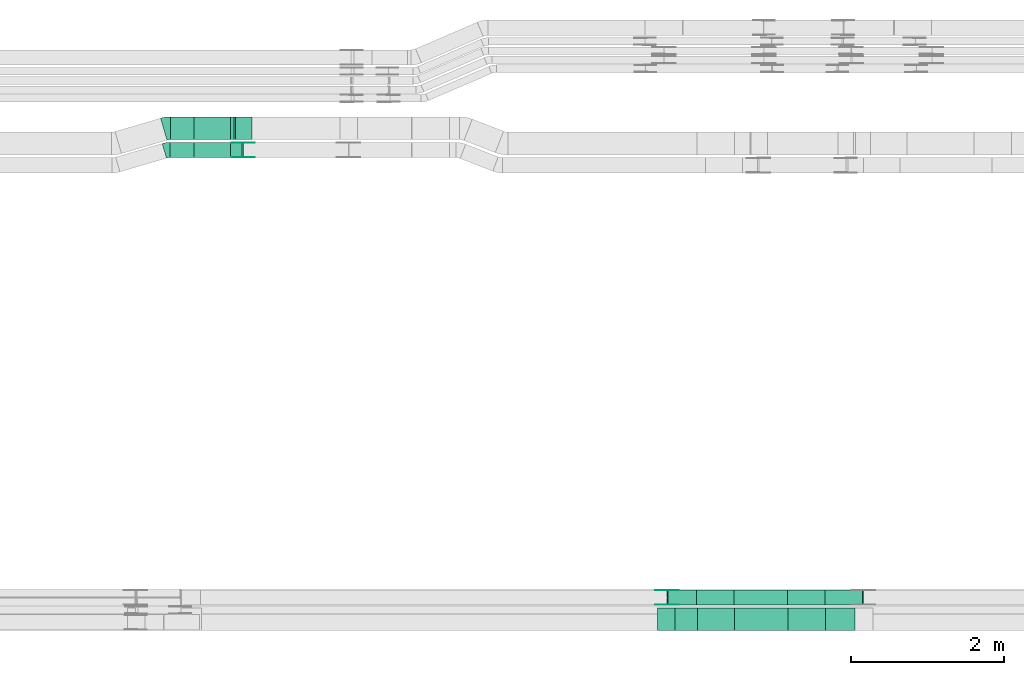
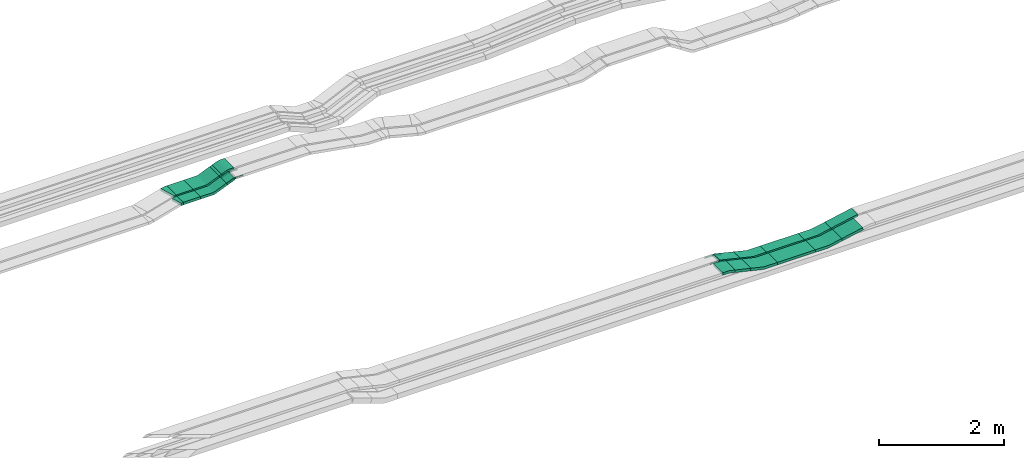
# One storey, part 14 of 28: 18 flow fittings, 10 flow segments.
"""IFC2X3 building model written with IfcOpenShell, lengths in millimetres."""

import ifcopenshell
import ifcopenshell.guid

model = None  # the IFC model being written
_history = None  # IfcOwnerHistory: only IFC2X3 demands one
_inside = {}  # id of a spatial element -> (the spatial element, [elements in it])
_under = {}  # id of a project, library or spatial element -> (it, [spatial elements below it])
_declared = {}  # id of a project -> (the project, [libraries it declares])
_typed = {}  # id of a type object -> (the type object, [elements of that type])
_made_of = {}  # id of a material, layer set ... -> (it, [elements and type objects made of it])


def new_model(schema):
    """Start an empty IFC model of exactly this schema.

    Asked for "IFC4X3", IfcOpenShell would pick the latest addendum, in which some entities
    have other attributes; the version numbers below select the first issue.
    IFC2X3 requires an IfcOwnerHistory on every rooted entity: one is made here for all.
    """
    global model, _history
    if schema == "IFC4X3":
        model = ifcopenshell.file(schema_version=(4, 3, 0, 0))
    else:
        model = ifcopenshell.file(schema=schema)
    _inside.clear()
    _under.clear()
    _declared.clear()
    _typed.clear()
    _made_of.clear()
    _history = None
    if model.schema == "IFC2X3":
        org = make("IfcOrganization", Name="unknown")
        user = make(
            "IfcPersonAndOrganization",
            ThePerson=make("IfcPerson", FamilyName="unknown"),
            TheOrganization=org,
        )
        app = make(
            "IfcApplication",
            ApplicationDeveloper=org,
            Version="unknown",
            ApplicationFullName="unknown",
            ApplicationIdentifier="unknown",
        )
        _history = make(
            "IfcOwnerHistory",
            OwningUser=user,
            OwningApplication=app,
            ChangeAction="ADDED",
            CreationDate=0,
        )
    return model


def make(cls, **values):
    """One entity of the class cls with the attributes given. An attribute that is None is left unset."""
    return model.create_entity(
        cls, **{name: value for name, value in values.items() if value is not None}
    )


def entity(cls, *values):
    """Any entity or typed value of the class cls, its attributes in the order of the schema. None: left unset."""
    e = model.create_entity(cls)
    for i, value in enumerate(values):
        if value is not None:
            e[i] = value
    return e


def rooted(cls, **values):
    """An entity with a GlobalId (a new one), such as an element, a storey or a relation."""
    return make(cls, GlobalId=ifcopenshell.guid.new(), OwnerHistory=_history, **values)


def si_unit(unit_type, name, prefix=None):
    """IfcSIUnit, for example si_unit("LENGTHUNIT", "METRE", prefix="MILLI")."""
    return make("IfcSIUnit", UnitType=unit_type, Prefix=prefix, Name=name)


def converted_unit(unit_type, name, factor, base, dimensions=None, offset=None):
    """IfcConversionBasedUnit, such as the inch: factor (a typed value) times the base unit."""
    return make(
        "IfcConversionBasedUnit"
        if offset is None
        else "IfcConversionBasedUnitWithOffset",
        ConversionOffset=offset,
        Dimensions=None
        if dimensions is None
        else entity("IfcDimensionalExponents", *dimensions),
        UnitType=unit_type,
        Name=name,
        ConversionFactor=make(
            "IfcMeasureWithUnit", ValueComponent=factor, UnitComponent=base
        ),
    )


def derived_unit(unit_type, elements):
    """IfcDerivedUnit: a product of units, each with its exponent."""
    return make(
        "IfcDerivedUnit",
        Elements=[
            make("IfcDerivedUnitElement", Unit=unit, Exponent=power)
            for unit, power in elements
        ],
        UnitType=unit_type,
    )


def assignment(units):
    """IfcUnitAssignment: the units of a project."""
    return None if units is None else make("IfcUnitAssignment", Units=units)


def point(xyz):
    """IfcCartesianPoint."""
    return None if xyz is None else make("IfcCartesianPoint", Coordinates=xyz)


def direction(xyz):
    """IfcDirection."""
    return None if xyz is None else make("IfcDirection", DirectionRatios=xyz)


def frame(location, z_axis=None, x_axis=None):
    """IfcAxis2Placement3D, a coordinate frame: its origin and axes. An axis left out is left unset."""
    return make(
        "IfcAxis2Placement3D",
        Location=point(location),
        Axis=direction(z_axis),
        RefDirection=direction(x_axis),
    )


def frame_2d(location, x_axis=None):
    """IfcAxis2Placement2D, a coordinate frame in the plane: its origin and x axis."""
    return make(
        "IfcAxis2Placement2D", Location=point(location), RefDirection=direction(x_axis)
    )


def origin():
    """The frame at (0, 0, 0) with its axes left unset."""
    return frame((0.0, 0.0, 0.0))


def origin_2d_with_axis():
    """The frame at (0, 0) in the plane with the x axis (1, 0) written out."""
    return frame_2d((0.0, 0.0), x_axis=(1.0, 0.0))


def place(relative_to, where):
    """IfcLocalPlacement: puts the frame where relative to a parent placement (None: the world)."""
    return make(
        "IfcLocalPlacement", PlacementRelTo=relative_to, RelativePlacement=where
    )


def context(
    kind, dimensions, precision=None, world=None, true_north=None, identifier=None
):
    """IfcGeometricRepresentationContext, for example the 3D "Model" context."""
    return make(
        "IfcGeometricRepresentationContext",
        ContextIdentifier=identifier,
        ContextType=kind,
        CoordinateSpaceDimension=dimensions,
        Precision=precision,
        WorldCoordinateSystem=world,
        TrueNorth=true_north,
    )


def subcontext(parent, identifier, kind, view, scale=None):
    """IfcGeometricRepresentationSubContext, for example "Body" below "Model"."""
    return make(
        "IfcGeometricRepresentationSubContext",
        ContextIdentifier=identifier,
        ContextType=kind,
        ParentContext=parent,
        TargetScale=scale,
        TargetView=view,
    )


def project(units=None, contexts=None):
    """IfcProject with its units and contexts."""
    return rooted(
        "IfcProject",
        Name="project",
        RepresentationContexts=contexts,
        UnitsInContext=assignment(units),
    )


def spatial(cls, under=None, at=None, **own):
    """A site, building, storey or space (cls), placed at a placement, below another one or the project."""
    s = rooted(cls, ObjectPlacement=at, **own)
    if under is not None:
        _under.setdefault(under.id(), (under, []))[1].append(s)
    return s


def polyline(points):
    """IfcPolyline through the points."""
    return make("IfcPolyline", Points=[point(p) for p in points])


def circle_curve(where, radius):
    """IfcCircle in the frame where."""
    return make("IfcCircle", Position=where, Radius=radius)


def parameter(value):
    """IfcParameterValue: where a trimmed curve begins or ends, as a parameter of its basis curve."""
    return model.create_entity("IfcParameterValue", value)


def trimmed(basis, trim1, trim2, sense, master):
    """IfcTrimmedCurve: the piece of a basis curve between two trims."""
    return make(
        "IfcTrimmedCurve",
        BasisCurve=basis,
        Trim1=trim1,
        Trim2=trim2,
        SenseAgreement=sense,
        MasterRepresentation=master,
    )


def segment(curve, same_sense, transition):
    """IfcCompositeCurveSegment."""
    return make(
        "IfcCompositeCurveSegment",
        Transition=transition,
        SameSense=same_sense,
        ParentCurve=curve,
    )


def composite_curve(segments, self_intersect=None):
    """IfcCompositeCurve: segments joined end to end."""
    return make("IfcCompositeCurve", Segments=segments, SelfIntersect=self_intersect)


def profile(cls, at=None, kind="AREA", **sizes):
    """A parametric profile (cls). Its sizes go by their IFC names, for example OverallWidth=200.0."""
    return make(cls, ProfileType=kind, Position=at, **sizes)


def rectangle(**sizes):
    """IfcRectangleProfileDef."""
    return profile("IfcRectangleProfileDef", **sizes)


def outline(outer, holes=None, kind="AREA"):
    """IfcArbitraryClosedProfileDef: a profile drawn as a closed curve; with holes, ...WithVoids."""
    if holes is None:
        return make("IfcArbitraryClosedProfileDef", ProfileType=kind, OuterCurve=outer)
    return make(
        "IfcArbitraryProfileDefWithVoids",
        ProfileType=kind,
        OuterCurve=outer,
        InnerCurves=holes,
    )


def extrude(swept, where, along, depth):
    """IfcExtrudedAreaSolid: the profile swept, set in the frame where, extruded along a direction by depth."""
    return make(
        "IfcExtrudedAreaSolid",
        SweptArea=swept,
        Position=where,
        ExtrudedDirection=direction(along),
        Depth=depth,
    )


def shape(context_of_items, identifier, shape_type, items):
    """IfcShapeRepresentation: the items that make up one representation, for example the "Body"."""
    return make(
        "IfcShapeRepresentation",
        ContextOfItems=context_of_items,
        RepresentationIdentifier=identifier,
        RepresentationType=shape_type,
        Items=items,
    )


def source(mapping_origin, context_of_items, identifier, shape_type, items):
    """IfcRepresentationMap: a shape defined once, which mapped items show again and again."""
    return make(
        "IfcRepresentationMap",
        MappingOrigin=mapping_origin,
        MappedRepresentation=shape(context_of_items, identifier, shape_type, items),
    )


def transform(
    local_origin,
    x_axis=None,
    y_axis=None,
    z_axis=None,
    scale=None,
    scale2=None,
    scale3=None,
    uniform=True,
):
    """IfcCartesianTransformationOperator3D, or its non-uniform kind. x_axis, y_axis, z_axis: its Axis1, 2, 3."""
    if uniform:
        return make(
            "IfcCartesianTransformationOperator3D",
            Axis1=direction(x_axis),
            Axis2=direction(y_axis),
            LocalOrigin=point(local_origin),
            Scale=scale,
            Axis3=direction(z_axis),
        )
    return make(
        "IfcCartesianTransformationOperator3DnonUniform",
        Axis1=direction(x_axis),
        Axis2=direction(y_axis),
        LocalOrigin=point(local_origin),
        Scale=scale,
        Axis3=direction(z_axis),
        Scale2=scale2,
        Scale3=scale3,
    )


def mapped(mapping_source, mapping_target):
    """IfcMappedItem: shows the shape of a source again, moved by a transform."""
    return make(
        "IfcMappedItem", MappingSource=mapping_source, MappingTarget=mapping_target
    )


def material(Name=None, Category=None):
    """IfcMaterial."""
    return make("IfcMaterial", Name=Name, Category=Category)


def made_of(thing, what):
    """Note that an element or type object is made of a material, layer set ...; save() writes the relation."""
    if what is not None:
        _made_of.setdefault(what.id(), (what, []))[1].append(thing)
    return thing


def type_object(cls, material=None, **own):
    """A type object (cls), such as IfcWallType, which elements share."""
    return made_of(rooted(cls, **own), material)


def type_shapes(of_type, sources):
    """Give a type object the sources (RepresentationMaps) that its elements show as mapped items."""
    of_type.RepresentationMaps = sources


def element(
    cls,
    number,
    at=None,
    inside=None,
    cuts=None,
    type_object=None,
    material=None,
    context=None,
    identifier="Body",
    shape_type=None,
    held_by="IfcProductDefinitionShape",
    body=None,
    shapes=None,
    **own,
):
    """One element of the class cls, such as IfcWall. Its Tag is "e" and its number.

    at: its placement. inside: the storey or other place that contains it. cuts: it is an
    opening in that element (IfcRelVoidsElement). A single representation is given by context,
    identifier, shape_type and body (its items); several are given by shapes. held_by: the class
    of the entity that holds the representations. save() writes the other relations.
    """
    e = rooted(cls, Tag="e%d" % number, ObjectPlacement=at, **own)
    if body is not None:
        shapes = [shape(context, identifier, shape_type, body)]
    if shapes is not None:
        e.Representation = make(held_by, Representations=shapes)
    if inside is not None:
        _inside.setdefault(inside.id(), (inside, []))[1].append(e)
    if cuts is not None:
        rooted(
            "IfcRelVoidsElement", RelatingBuildingElement=cuts, RelatedOpeningElement=e
        )
    if type_object is not None:
        _typed.setdefault(type_object.id(), (type_object, []))[1].append(e)
    return made_of(e, material)


def aggregate(whole, parts):
    """IfcRelAggregates: a whole, such as a stair, and the parts it consists of."""
    return rooted("IfcRelAggregates", RelatingObject=whole, RelatedObjects=parts)


def save(model, path):
    """Write the relations noted so far, then the file.

    IfcRelAggregates (storeys below a building ...), IfcRelContainedInSpatialStructure (elements
    in a storey), IfcRelDefinesByType, IfcRelAssociatesMaterial and IfcRelDeclares: one each for
    every whole, place, type object, material and project.
    """
    for whole, parts in _under.values():
        aggregate(whole, parts)
    for where, things in _inside.values():
        rooted(
            "IfcRelContainedInSpatialStructure",
            RelatedElements=things,
            RelatingStructure=where,
        )
    for kind, things in _typed.values():
        rooted("IfcRelDefinesByType", RelatedObjects=things, RelatingType=kind)
    for what, things in _made_of.values():
        rooted("IfcRelAssociatesMaterial", RelatedObjects=things, RelatingMaterial=what)
    for by, libraries in _declared.values():
        rooted("IfcRelDeclares", RelatingContext=by, RelatedDefinitions=libraries)
    model.write(path)


model = new_model("IFC2X3")

# Units and contexts
model_context = context("Model", 3, precision=0.01, world=origin(), true_north=direction((6.12303176911189e-17, 1.0)))
body_context = subcontext(model_context, "Body", "Model", "MODEL_VIEW")
ifc_project = project(units=[si_unit("LENGTHUNIT", "METRE", prefix="MILLI"), si_unit("AREAUNIT", "SQUARE_METRE"), si_unit("VOLUMEUNIT", "CUBIC_METRE"), converted_unit("PLANEANGLEUNIT", "DEGREE", entity("IfcRatioMeasure", 0.0174532925199433), si_unit("PLANEANGLEUNIT", "RADIAN"), dimensions=[0, 0, 0, 0, 0, 0, 0]), si_unit("MASSUNIT", "GRAM", prefix="KILO"), derived_unit("MASSDENSITYUNIT", [(si_unit("MASSUNIT", "GRAM", prefix="KILO"), 1), (si_unit("LENGTHUNIT", "METRE"), -3)]), derived_unit("MOMENTOFINERTIAUNIT", [(si_unit("LENGTHUNIT", "METRE"), 4)]), si_unit("TIMEUNIT", "SECOND"), si_unit("FREQUENCYUNIT", "HERTZ"), si_unit("THERMODYNAMICTEMPERATUREUNIT", "DEGREE_CELSIUS"), derived_unit("THERMALTRANSMITTANCEUNIT", [(si_unit("MASSUNIT", "GRAM", prefix="KILO"), 1), (si_unit("THERMODYNAMICTEMPERATUREUNIT", "KELVIN"), -1), (si_unit("TIMEUNIT", "SECOND"), -3)]), derived_unit("VOLUMETRICFLOWRATEUNIT", [(si_unit("LENGTHUNIT", "METRE"), 3), (si_unit("TIMEUNIT", "SECOND"), -1)]), derived_unit("MASSFLOWRATEUNIT", [(si_unit("MASSUNIT", "GRAM", prefix="KILO"), 1), (si_unit("TIMEUNIT", "SECOND"), -1)]), derived_unit("ROTATIONALFREQUENCYUNIT", [(si_unit("TIMEUNIT", "SECOND"), -1)]), si_unit("ELECTRICCURRENTUNIT", "AMPERE"), si_unit("ELECTRICVOLTAGEUNIT", "VOLT"), si_unit("POWERUNIT", "WATT"), si_unit("FORCEUNIT", "NEWTON", prefix="KILO"), si_unit("ILLUMINANCEUNIT", "LUX"), si_unit("LUMINOUSFLUXUNIT", "LUMEN"), si_unit("LUMINOUSINTENSITYUNIT", "CANDELA"), derived_unit("USERDEFINED", [(si_unit("MASSUNIT", "GRAM", prefix="KILO"), -1), (si_unit("LENGTHUNIT", "METRE"), -2), (si_unit("TIMEUNIT", "SECOND"), 3), (si_unit("LUMINOUSFLUXUNIT", "LUMEN"), 1)]), derived_unit("LINEARVELOCITYUNIT", [(si_unit("LENGTHUNIT", "METRE"), 1), (si_unit("TIMEUNIT", "SECOND"), -1)]), si_unit("PRESSUREUNIT", "PASCAL"), derived_unit("USERDEFINED", [(si_unit("LENGTHUNIT", "METRE"), -2), (si_unit("MASSUNIT", "GRAM", prefix="KILO"), 1), (si_unit("TIMEUNIT", "SECOND"), -2)]), derived_unit("LINEARFORCEUNIT", [(si_unit("MASSUNIT", "GRAM", prefix="KILO"), 1), (si_unit("LENGTHUNIT", "METRE"), 1), (si_unit("TIMEUNIT", "SECOND"), -2), (si_unit("LENGTHUNIT", "METRE"), -1)]), derived_unit("PLANARFORCEUNIT", [(si_unit("MASSUNIT", "GRAM", prefix="KILO"), 1), (si_unit("LENGTHUNIT", "METRE"), 1), (si_unit("TIMEUNIT", "SECOND"), -2), (si_unit("LENGTHUNIT", "METRE"), -2)])], contexts=[model_context])

# Site, building, storey
site_placement = place(None, origin())
site = spatial("IfcSite", under=ifc_project, at=site_placement, CompositionType="ELEMENT")
building_placement = place(site_placement, origin())
building = spatial("IfcBuilding", under=site, at=building_placement, CompositionType="ELEMENT")
storey_placement = place(building_placement, frame((0.0, 0.0, 15900.0)))
storey = spatial("IfcBuildingStorey", under=building, at=storey_placement, CompositionType="ELEMENT", Elevation=15900.0)

# Flow segments
cable_carrier_segment_type = type_object("IfcCableCarrierSegmentType", PredefinedType="CABLETRAYSEGMENT")
flow_segment_1_placement = place(storey_placement, frame((50193.5, 8550.15, 2670.0)))
element("IfcFlowSegment", 1, at=flow_segment_1_placement, inside=storey, type_object=cable_carrier_segment_type, context=body_context, shape_type="SweptSolid", body=[
    extrude(rectangle(XDim=698.184892642371, YDim=200.0, at=origin_2d_with_axis()), frame((349.09, 100.0, 0.0), z_axis=(0.0, 0.0, 1.0), x_axis=(-1.0, 0.0, 0.0)), (0.0, 0.0, 1.0), 50.0000000000016),
])
flow_segment_2_placement = place(storey_placement, frame((50203.18, 8215.15, 2670.0)))
element("IfcFlowSegment", 2, at=flow_segment_2_placement, inside=storey, type_object=cable_carrier_segment_type, context=body_context, shape_type="SweptSolid", body=[
    extrude(rectangle(XDim=698.304534220649, YDim=300.000000000001, at=origin_2d_with_axis()), frame((349.15, 150.0, 0.0), z_axis=(0.0, 0.0, 1.0), x_axis=(-1.0, 0.0, 0.0)), (0.0, 0.0, 1.0), 50.0000000000016),
])
flow_segment_3_placement = place(storey_placement, frame((49413.95, 8215.15, 2727.48)))
element("IfcFlowSegment", 3, at=flow_segment_3_placement, inside=storey, type_object=cable_carrier_segment_type, context=body_context, shape_type="SweptSolid", body=[
    extrude(rectangle(XDim=50.0000000000005, YDim=296.977603274496, at=frame_2d((0.0, 0.0), x_axis=(0.0, 1.0))), frame((150.29, 0.0, 58.04), z_axis=(0.0, 1.0, 0.0), x_axis=(-0.973915582918312, 0.0, 0.226910637363885)), (0.0, 0.0, 1.0), 300.000000000001),
])
flow_segment_4_placement = place(storey_placement, frame((51391.6, 8215.15, 2719.91)))
element("IfcFlowSegment", 4, at=flow_segment_4_placement, inside=storey, type_object=cable_carrier_segment_type, context=body_context, shape_type="SweptSolid", body=[
    extrude(rectangle(XDim=50.0000000000021, YDim=300.000000000001, at=origin_2d_with_axis()), frame((4.94, 150.0, 24.51), z_axis=(0.980265659659677, 0.0, 0.197684689574023), x_axis=(-0.197684689574023, 0.0, 0.980265659659677)), (0.0, 0.0, 1.0), 395.138063612391),
])
flow_segment_5_placement = place(storey_placement, frame((49317.61, 8550.15, 2729.27)))
element("IfcFlowSegment", 5, at=flow_segment_5_placement, inside=storey, type_object=cable_carrier_segment_type, context=body_context, shape_type="SweptSolid", body=[
    extrude(rectangle(XDim=50.0000000000019, YDim=200.0, at=origin_2d_with_axis()), frame((5.84, 100.0, 114.69), z_axis=(0.972286194973467, 0.0, -0.233793830252249), x_axis=(0.233793830252249, 0.0, 0.972286194973467)), (0.0, 0.0, 1.0), 386.603864196462),
])
flow_segment_6_placement = place(storey_placement, frame((51381.8, 8550.15, 2719.91)))
element("IfcFlowSegment", 6, at=flow_segment_6_placement, inside=storey, type_object=cable_carrier_segment_type, context=body_context, shape_type="SweptSolid", body=[
    extrude(rectangle(XDim=50.0000000000021, YDim=200.0, at=origin_2d_with_axis()), frame((4.94, 100.0, 24.51), z_axis=(0.980265659659677, 0.0, 0.197684689574023), x_axis=(-0.197684689574023, 0.0, 0.980265659659677)), (0.0, 0.0, 1.0), 504.893418932324),
])
flow_segment_7_placement = place(storey_placement, frame((42826.4, 14635.03, 2675.0)))
element("IfcFlowSegment", 7, at=flow_segment_7_placement, inside=storey, type_object=cable_carrier_segment_type, context=body_context, shape_type="SweptSolid", body=[
    extrude(rectangle(XDim=307.551244257685, YDim=300.000000000001, at=origin_2d_with_axis()), frame((153.78, 150.0, 0.0)), (0.0, 0.0, 1.0), 50.0000000000016),
])
flow_segment_8_placement = place(storey_placement, frame((42819.2, 14400.03, 2675.0)))
element("IfcFlowSegment", 8, at=flow_segment_8_placement, inside=storey, type_object=cable_carrier_segment_type, context=body_context, shape_type="SweptSolid", body=[
    extrude(rectangle(XDim=314.751695724342, YDim=199.999999999998, at=origin_2d_with_axis()), frame((157.38, 100.0, 0.0), z_axis=(0.0, 0.0, 1.0), x_axis=(-1.0, 0.0, 0.0)), (0.0, 0.0, 1.0), 50.0000000000016),
])
flow_segment_9_placement = place(storey_placement, frame((43614.81, 14635.03, 2774.46)))
element("IfcFlowSegment", 9, at=flow_segment_9_placement, inside=storey, type_object=cable_carrier_segment_type, context=body_context, shape_type="SweptSolid", body=[
    extrude(rectangle(XDim=49.9999999999987, YDim=48.6041297172027, at=frame_2d((0.0, 0.0), x_axis=(0.0, 1.0))), frame((32.02, 0.0, 32.4), z_axis=(0.0, 1.0, 0.0), x_axis=(0.92387953251118, 0.0, 0.382683432365348)), (0.0, 0.0, 1.0), 300.000000000001),
])
flow_segment_10_placement = place(storey_placement, frame((43614.81, 14400.03, 2774.46)))
element("IfcFlowSegment", 10, at=flow_segment_10_placement, inside=storey, type_object=cable_carrier_segment_type, context=body_context, shape_type="SweptSolid", body=[
    extrude(rectangle(XDim=49.9999999999987, YDim=156.412966816902, at=frame_2d((0.0, 0.0), x_axis=(0.0, 1.0))), frame((81.82, 0.0, 53.03), z_axis=(0.0, 1.0, 0.0), x_axis=(0.923879532511178, 0.0, 0.382683432365351)), (0.0, 0.0, 1.0), 199.999999999998),
])

# Flow fittings
ifc_material_1 = material()
cable_carrier_fitting_type_1 = type_object("IfcCableCarrierFittingType", Name="470_DKC_S5_CS 90 internal vertical angle:-", PredefinedType="NOTDEFINED", material=ifc_material_1)
shared_shape_1 = source(origin(), body_context, "Body", "SweptSolid", [
    extrude(outline(composite_curve([segment(polyline([(-248.69, -40.12), (-14.36, -40.12)]), True, "CONTINUOUS"), segment(trimmed(circle_curve(frame_2d((-14.36, 124.88), x_axis=(0.0, -1.0)), 164.999999999999), [parameter(0.0)], [parameter(13.115255993311)], True, "PARAMETER"), True, "CONTINUOUS"), segment(polyline([(23.08, -35.82), (251.31, 17.36)]), True, "CONTINUOUS"), segment(polyline([(251.31, 17.36), (239.96, 66.05)]), True, "CONTINUOUS"), segment(polyline([(239.96, 66.05), (11.74, 12.88)]), True, "CONTINUOUS"), segment(trimmed(circle_curve(frame_2d((-14.36, 124.88), x_axis=(0.0, -1.0)), 114.999999999999), [parameter(0.0)], [parameter(13.115255993311)], True, "PARAMETER"), False, "CONTINUOUS"), segment(polyline([(-14.36, 9.88), (-248.69, 9.88)]), True, "CONTINUOUS"), segment(polyline([(-248.69, 9.88), (-248.69, -40.12)]), True, "CONTINUOUS")], self_intersect=False)), frame((-1.74, 15.12, -150.0)), (0.0, 0.0, 1.0), 300.0),
])
type_shapes(cable_carrier_fitting_type_1, [shared_shape_1])
flow_fitting_1_placement = place(storey_placement, frame((49952.75, 8365.15, 2695.0), z_axis=(0.0, 1.0, 0.0), x_axis=(-1.0, 0.0, 0.0)))
element("IfcFlowFitting", 11, at=flow_fitting_1_placement, inside=storey, type_object=cable_carrier_fitting_type_1, material=ifc_material_1, Name="470_DKC_S5_CS 90 internal vertical angle:-", ObjectType="470_DKC_S5_CS 90 internal vertical angle:-", context=body_context, shape_type="MappedRepresentation", body=[
    mapped(shared_shape_1, transform((0.0, 0.0, 0.0), scale=1.0)),
])
cable_carrier_fitting_type_2 = type_object("IfcCableCarrierFittingType", Name="470_DKC_S5_CD 90 external vertical angle:-", PredefinedType="NOTDEFINED", material=ifc_material_1)
shared_shape_2 = source(origin(), body_context, "Body", "SweptSolid", [
    extrude(outline(composite_curve([segment(polyline([(-112.78, -32.52), (-18.1, -32.52)]), True, "CONTINUOUS"), segment(trimmed(circle_curve(frame_2d((-18.1, 157.48), x_axis=(0.0, -1.0)), 189.999999999999), [parameter(0.0)], [parameter(13.1152559933101)], True, "PARAMETER"), True, "CONTINUOUS"), segment(polyline([(25.01, -27.57), (117.22, -6.08)]), True, "CONTINUOUS"), segment(polyline([(117.22, -6.08), (105.87, 42.61)]), True, "CONTINUOUS"), segment(polyline([(105.87, 42.61), (13.66, 21.13)]), True, "CONTINUOUS"), segment(trimmed(circle_curve(frame_2d((-18.1, 157.48), x_axis=(0.0, -1.0)), 139.999999999999), [parameter(0.0)], [parameter(13.1152559933101)], True, "PARAMETER"), False, "CONTINUOUS"), segment(polyline([(-18.1, 17.48), (-112.78, 17.48)]), True, "CONTINUOUS"), segment(polyline([(-112.78, 17.48), (-112.78, -32.52)]), True, "CONTINUOUS")], self_intersect=False)), frame((-0.86, 7.52, -150.0)), (0.0, 0.0, 1.0), 300.0),
])
type_shapes(cable_carrier_fitting_type_2, [shared_shape_2])
flow_fitting_2_placement = place(storey_placement, frame((49308.94, 8365.15, 2845.0), z_axis=(0.0, 1.0, 0.0), x_axis=(1.0, 0.0, 0.0)))
element("IfcFlowFitting", 12, at=flow_fitting_2_placement, inside=storey, type_object=cable_carrier_fitting_type_2, material=ifc_material_1, Name="470_DKC_S5_CD 90 external vertical angle:-", ObjectType="470_DKC_S5_CD 90 external vertical angle:-", context=body_context, shape_type="MappedRepresentation", body=[
    mapped(shared_shape_2, transform((0.0, 0.0, 0.0), scale=1.0)),
])
cable_carrier_fitting_type_3 = type_object("IfcCableCarrierFittingType", Name="470_DKC_S5_CS 90 internal vertical angle:-", PredefinedType="NOTDEFINED", material=ifc_material_1)
shared_shape_3 = source(origin(), body_context, "Body", "SweptSolid", [
    extrude(outline(composite_curve([segment(polyline([(-248.69, -38.05), (-12.67, -38.05)]), True, "CONTINUOUS"), segment(trimmed(circle_curve(frame_2d((-12.67, 126.95), x_axis=(0.0, -1.0)), 164.999999999999), [parameter(0.0)], [parameter(11.4015985350609)], True, "PARAMETER"), True, "CONTINUOUS"), segment(polyline([(19.94, -34.79), (251.31, 11.87)]), True, "CONTINUOUS"), segment(polyline([(251.31, 11.87), (241.42, 60.88)]), True, "CONTINUOUS"), segment(polyline([(241.42, 60.88), (10.06, 14.22)]), True, "CONTINUOUS"), segment(trimmed(circle_curve(frame_2d((-12.67, 126.95), x_axis=(0.0, -1.0)), 114.999999999999), [parameter(0.0)], [parameter(11.4015985350609)], True, "PARAMETER"), False, "CONTINUOUS"), segment(polyline([(-12.67, 11.95), (-248.69, 11.95)]), True, "CONTINUOUS"), segment(polyline([(-248.69, 11.95), (-248.69, -38.05)]), True, "CONTINUOUS")], self_intersect=False)), frame((-1.3, 13.05, -150.0)), (0.0, 0.0, 1.0), 300.0),
])
type_shapes(cable_carrier_fitting_type_3, [shared_shape_3])
flow_fitting_3_placement = place(storey_placement, frame((51151.48, 8365.15, 2695.0), z_axis=(0.0, -1.0, 0.0), x_axis=(1.0, 0.0, 0.0)))
element("IfcFlowFitting", 13, at=flow_fitting_3_placement, inside=storey, type_object=cable_carrier_fitting_type_3, material=ifc_material_1, Name="470_DKC_S5_CS 90 internal vertical angle:-", ObjectType="470_DKC_S5_CS 90 internal vertical angle:-", context=body_context, shape_type="MappedRepresentation", body=[
    mapped(shared_shape_3, transform((0.0, 0.0, 0.0), scale=1.0)),
])
cable_carrier_fitting_type_4 = type_object("IfcCableCarrierFittingType", Name="470_DKC_S5_CS 90 internal vertical angle:-", PredefinedType="NOTDEFINED", material=ifc_material_1)
shared_shape_4 = source(origin(), body_context, "Body", "SweptSolid", [
    extrude(outline(composite_curve([segment(polyline([(-248.7, -40.61), (-14.74, -40.61)]), True, "CONTINUOUS"), segment(trimmed(circle_curve(frame_2d((-14.74, 124.39), x_axis=(0.0, -1.0)), 164.999999999999), [parameter(0.0)], [parameter(13.5205338655362)], True, "PARAMETER"), True, "CONTINUOUS"), segment(polyline([(23.83, -36.04), (251.3, 18.66)]), True, "CONTINUOUS"), segment(polyline([(251.3, 18.66), (239.61, 67.27)]), True, "CONTINUOUS"), segment(polyline([(239.61, 67.27), (12.14, 12.57)]), True, "CONTINUOUS"), segment(trimmed(circle_curve(frame_2d((-14.74, 124.39), x_axis=(0.0, -1.0)), 114.999999999999), [parameter(0.0)], [parameter(13.5205338655362)], True, "PARAMETER"), False, "CONTINUOUS"), segment(polyline([(-14.74, 9.39), (-248.7, 9.39)]), True, "CONTINUOUS"), segment(polyline([(-248.7, 9.39), (-248.7, -40.61)]), True, "CONTINUOUS")], self_intersect=False)), frame((-1.85, 15.61, -100.0)), (0.0, 0.0, 1.0), 200.0),
])
type_shapes(cable_carrier_fitting_type_4, [shared_shape_4])
flow_fitting_4_placement = place(storey_placement, frame((49942.95, 8650.15, 2695.0), z_axis=(0.0, 1.0, 0.0), x_axis=(-1.0, 0.0, 0.0)))
element("IfcFlowFitting", 14, at=flow_fitting_4_placement, inside=storey, type_object=cable_carrier_fitting_type_4, material=ifc_material_1, Name="470_DKC_S5_CS 90 internal vertical angle:-", ObjectType="470_DKC_S5_CS 90 internal vertical angle:-", context=body_context, shape_type="MappedRepresentation", body=[
    mapped(shared_shape_4, transform((0.0, 0.0, 0.0), scale=1.0)),
])
cable_carrier_fitting_type_5 = type_object("IfcCableCarrierFittingType", Name="470_DKC_S5_CS 90 internal vertical angle:-", PredefinedType="NOTDEFINED", material=ifc_material_1)
shared_shape_5 = source(origin(), body_context, "Body", "SweptSolid", [
    extrude(outline(composite_curve([segment(polyline([(-248.69, -38.05), (-12.67, -38.05)]), True, "CONTINUOUS"), segment(trimmed(circle_curve(frame_2d((-12.67, 126.95), x_axis=(0.0, -1.0)), 164.999999999999), [parameter(0.0)], [parameter(11.4015985350609)], True, "PARAMETER"), True, "CONTINUOUS"), segment(polyline([(19.94, -34.79), (251.31, 11.87)]), True, "CONTINUOUS"), segment(polyline([(251.31, 11.87), (241.42, 60.88)]), True, "CONTINUOUS"), segment(polyline([(241.42, 60.88), (10.06, 14.22)]), True, "CONTINUOUS"), segment(trimmed(circle_curve(frame_2d((-12.67, 126.95), x_axis=(0.0, -1.0)), 114.999999999999), [parameter(0.0)], [parameter(11.4015985350609)], True, "PARAMETER"), False, "CONTINUOUS"), segment(polyline([(-12.67, 11.95), (-248.69, 11.95)]), True, "CONTINUOUS"), segment(polyline([(-248.69, 11.95), (-248.69, -38.05)]), True, "CONTINUOUS")], self_intersect=False)), frame((-1.3, 13.05, -100.0)), (0.0, 0.0, 1.0), 200.0),
])
type_shapes(cable_carrier_fitting_type_5, [shared_shape_5])
flow_fitting_5_placement = place(storey_placement, frame((51141.68, 8650.15, 2695.0), z_axis=(0.0, -1.0, 0.0), x_axis=(1.0, 0.0, 0.0)))
element("IfcFlowFitting", 15, at=flow_fitting_5_placement, inside=storey, type_object=cable_carrier_fitting_type_5, material=ifc_material_1, Name="470_DKC_S5_CS 90 internal vertical angle:-", ObjectType="470_DKC_S5_CS 90 internal vertical angle:-", context=body_context, shape_type="MappedRepresentation", body=[
    mapped(shared_shape_5, transform((0.0, 0.0, 0.0), scale=1.0)),
])
ifc_material_2 = material(Name="G")
cable_carrier_fitting_type_6 = type_object("IfcCableCarrierFittingType", PredefinedType="NOTDEFINED", material=ifc_material_2)
shared_shape_6 = source(origin(), body_context, "Body", "SweptSolid", [
    extrude(outline(composite_curve([segment(trimmed(circle_curve(frame_2d((-44.59, 0.0), x_axis=(1.0, 0.0)), 12.5), [parameter(90.0000000000007)], [parameter(270.0)], True, "PARAMETER"), True, "CONTINUOUS"), segment(polyline([(-44.59, -12.5), (-33.09, -12.5)]), True, "CONTINUOUS"), segment(polyline([(-33.09, -12.5), (-31.23, -14.5)]), True, "CONTINUOUS"), segment(polyline([(-31.23, -14.5), (108.91, -14.5)]), True, "CONTINUOUS"), segment(polyline([(108.91, -14.5), (108.91, 14.5)]), True, "CONTINUOUS"), segment(polyline([(108.91, 14.5), (-31.23, 14.5)]), True, "CONTINUOUS"), segment(polyline([(-31.23, 14.5), (-33.09, 12.5)]), True, "CONTINUOUS"), segment(polyline([(-33.09, 12.5), (-44.59, 12.5)]), True, "CONTINUOUS")], self_intersect=False)), frame((44.59, 0.0, 0.0), z_axis=(0.0, 0.0, -1.0), x_axis=(1.0, 0.0, 0.0)), (0.0, 0.0, -1.0), 2.0),
])
type_shapes(cable_carrier_fitting_type_6, [shared_shape_6])
flow_fitting_6_placement = place(storey_placement, frame((49319.14, 8745.61, 2845.0), z_axis=(0.0, 1.0, 0.0), x_axis=(0.972286194973484, 0.0, -0.233793830252179)))
element("IfcFlowFitting", 16, at=flow_fitting_6_placement, inside=storey, type_object=cable_carrier_fitting_type_6, material=ifc_material_2, context=body_context, shape_type="MappedRepresentation", body=[
    mapped(shared_shape_6, transform((0.0, 0.0, 0.0), scale=1.0)),
])
cable_carrier_fitting_type_7 = type_object("IfcCableCarrierFittingType", PredefinedType="NOTDEFINED", material=ifc_material_2)
type_shapes(cable_carrier_fitting_type_7, [shared_shape_6])
flow_fitting_7_placement = place(storey_placement, frame((49319.14, 8556.69, 2845.0), z_axis=(0.0, -1.0, 0.0), x_axis=(-1.0, 0.0, 0.0)))
element("IfcFlowFitting", 17, at=flow_fitting_7_placement, inside=storey, type_object=cable_carrier_fitting_type_7, material=ifc_material_2, context=body_context, shape_type="MappedRepresentation", body=[
    mapped(shared_shape_6, transform((0.0, 0.0, 0.0), scale=1.0)),
])
flow_fitting_8_placement = place(storey_placement, frame((43775.14, 14595.49, 2860.0), z_axis=(0.0, 1.0, 0.0), x_axis=(1.0, 0.0, 0.0)))
element("IfcFlowFitting", 18, at=flow_fitting_8_placement, inside=storey, type_object=cable_carrier_fitting_type_6, material=ifc_material_2, context=body_context, shape_type="MappedRepresentation", body=[
    mapped(shared_shape_6, transform((0.0, 0.0, 0.0), scale=1.0)),
])
flow_fitting_9_placement = place(storey_placement, frame((43775.14, 14406.57, 2860.0), z_axis=(0.0, -1.0, 0.0), x_axis=(-0.923879532511193, 0.0, -0.382683432365316)))
element("IfcFlowFitting", 19, at=flow_fitting_9_placement, inside=storey, type_object=cable_carrier_fitting_type_7, material=ifc_material_2, context=body_context, shape_type="MappedRepresentation", body=[
    mapped(shared_shape_6, transform((0.0, 0.0, 0.0), scale=1.0)),
])
cable_carrier_fitting_type_8 = type_object("IfcCableCarrierFittingType", PredefinedType="NOTDEFINED", material=ifc_material_2)
shared_shape_7 = source(origin(), body_context, "Body", "SweptSolid", [
    extrude(outline(composite_curve([segment(trimmed(circle_curve(frame_2d((-44.59, 0.0), x_axis=(1.0, 0.0)), 12.5), [parameter(90.0000000000007)], [parameter(270.0)], True, "PARAMETER"), True, "CONTINUOUS"), segment(polyline([(-44.59, -12.5), (-33.09, -12.5)]), True, "CONTINUOUS"), segment(polyline([(-33.09, -12.5), (-31.23, -14.5)]), True, "CONTINUOUS"), segment(polyline([(-31.23, -14.5), (108.91, -14.5)]), True, "CONTINUOUS"), segment(polyline([(108.91, -14.5), (108.91, 14.5)]), True, "CONTINUOUS"), segment(polyline([(108.91, 14.5), (-31.23, 14.5)]), True, "CONTINUOUS"), segment(polyline([(-31.23, 14.5), (-33.09, 12.5)]), True, "CONTINUOUS"), segment(polyline([(-33.09, 12.5), (-44.59, 12.5)]), True, "CONTINUOUS")], self_intersect=False)), frame((44.59, 0.0, 0.0)), (0.0, 0.0, 1.0), 2.0),
])
type_shapes(cable_carrier_fitting_type_8, [shared_shape_7])
flow_fitting_10_placement = place(storey_placement, frame((49319.14, 8554.69, 2845.0), z_axis=(0.0, -1.0, 0.0), x_axis=(0.972286194973484, 0.0, -0.233793830252179)))
element("IfcFlowFitting", 20, at=flow_fitting_10_placement, inside=storey, type_object=cable_carrier_fitting_type_8, material=ifc_material_2, context=body_context, shape_type="MappedRepresentation", body=[
    mapped(shared_shape_7, transform((0.0, 0.0, 0.0), scale=1.0)),
])
cable_carrier_fitting_type_9 = type_object("IfcCableCarrierFittingType", PredefinedType="NOTDEFINED", material=ifc_material_2)
type_shapes(cable_carrier_fitting_type_9, [shared_shape_7])
flow_fitting_11_placement = place(storey_placement, frame((49319.14, 8743.61, 2845.0), z_axis=(0.0, 1.0, 0.0), x_axis=(-1.0, 0.0, 0.0)))
element("IfcFlowFitting", 21, at=flow_fitting_11_placement, inside=storey, type_object=cable_carrier_fitting_type_9, material=ifc_material_2, context=body_context, shape_type="MappedRepresentation", body=[
    mapped(shared_shape_7, transform((0.0, 0.0, 0.0), scale=1.0)),
])
flow_fitting_12_placement = place(storey_placement, frame((43775.14, 14404.57, 2860.0), z_axis=(0.0, -1.0, 0.0), x_axis=(1.0, 0.0, 0.0)))
element("IfcFlowFitting", 22, at=flow_fitting_12_placement, inside=storey, type_object=cable_carrier_fitting_type_8, material=ifc_material_2, context=body_context, shape_type="MappedRepresentation", body=[
    mapped(shared_shape_7, transform((0.0, 0.0, 0.0), scale=1.0)),
])
flow_fitting_13_placement = place(storey_placement, frame((43775.14, 14593.49, 2860.0), z_axis=(0.0, 1.0, 0.0), x_axis=(-0.923879532511193, 0.0, -0.382683432365316)))
element("IfcFlowFitting", 23, at=flow_fitting_13_placement, inside=storey, type_object=cable_carrier_fitting_type_9, material=ifc_material_2, context=body_context, shape_type="MappedRepresentation", body=[
    mapped(shared_shape_7, transform((0.0, 0.0, 0.0), scale=1.0)),
])
cable_carrier_fitting_type_10 = type_object("IfcCableCarrierFittingType", Name="470_DKC_S5_Variable Angle Elbow 0-45:-", PredefinedType="NOTDEFINED", material=ifc_material_1)
shared_shape_8 = source(origin(), body_context, "Body", "SweptSolid", [
    extrude(outline(composite_curve([segment(polyline([(-36.26, -105.15), (-35.26, -105.15)]), True, "CONTINUOUS"), segment(trimmed(circle_curve(frame_2d((-35.26, 244.85), x_axis=(0.0, -1.0)), 350.0), [parameter(0.0)], [parameter(16.3895403340349)], True, "PARAMETER"), True, "CONTINUOUS"), segment(polyline([(63.5, -90.93), (64.46, -90.65)]), True, "CONTINUOUS"), segment(polyline([(64.46, -90.65), (8.02, 101.23)]), True, "CONTINUOUS"), segment(polyline([(8.02, 101.23), (7.06, 100.95)]), True, "CONTINUOUS"), segment(trimmed(circle_curve(frame_2d((-35.26, 244.85), x_axis=(0.0, -1.0)), 150.0), [parameter(0.0)], [parameter(16.3895403340349)], True, "PARAMETER"), False, "CONTINUOUS"), segment(polyline([(-35.26, 94.85), (-36.26, 94.85)]), True, "CONTINUOUS"), segment(polyline([(-36.26, 94.85), (-36.26, -105.15)]), True, "CONTINUOUS")], self_intersect=False)), frame((-0.74, 5.15, -25.0)), (0.0, 0.0, 1.0), 50.0000000000005),
])
type_shapes(cable_carrier_fitting_type_10, [shared_shape_8])
flow_fitting_14_placement = place(storey_placement, frame((42782.19, 14500.03, 2700.0), z_axis=(0.0, 0.0, 1.0), x_axis=(-1.0, 0.0, 0.0)))
element("IfcFlowFitting", 24, at=flow_fitting_14_placement, inside=storey, type_object=cable_carrier_fitting_type_10, material=ifc_material_1, Name="470_DKC_S5_Variable Angle Elbow 0-45:-", ObjectType="470_DKC_S5_Variable Angle Elbow 0-45:-", context=body_context, shape_type="MappedRepresentation", body=[
    mapped(shared_shape_8, transform((0.0, 0.0, 0.0), scale=1.0)),
])
cable_carrier_fitting_type_11 = type_object("IfcCableCarrierFittingType", Name="470_DKC_S5_Variable Angle Elbow 0-45:-", PredefinedType="NOTDEFINED", material=ifc_material_1)
shared_shape_9 = source(origin(), body_context, "Body", "SweptSolid", [
    extrude(outline(composite_curve([segment(polyline([(-43.31, -156.17), (-42.31, -156.17)]), True, "CONTINUOUS"), segment(trimmed(circle_curve(frame_2d((-42.31, 293.83), x_axis=(0.0, -1.0)), 450.0), [parameter(0.0)], [parameter(16.3895403340363)], True, "PARAMETER"), True, "CONTINUOUS"), segment(polyline([(84.66, -137.88), (85.62, -137.6)]), True, "CONTINUOUS"), segment(polyline([(85.62, -137.6), (0.97, 150.21)]), True, "CONTINUOUS"), segment(polyline([(0.97, 150.21), (0.01, 149.93)]), True, "CONTINUOUS"), segment(trimmed(circle_curve(frame_2d((-42.31, 293.83), x_axis=(0.0, -1.0)), 150.0), [parameter(0.0)], [parameter(16.3895403340363)], True, "PARAMETER"), False, "CONTINUOUS"), segment(polyline([(-42.31, 143.83), (-43.31, 143.83)]), True, "CONTINUOUS"), segment(polyline([(-43.31, 143.83), (-43.31, -156.17)]), True, "CONTINUOUS")], self_intersect=False)), frame((-0.89, 6.17, -25.0)), (0.0, 0.0, 1.0), 49.9999999999995),
])
type_shapes(cable_carrier_fitting_type_11, [shared_shape_9])
flow_fitting_15_placement = place(storey_placement, frame((42782.19, 14785.03, 2700.0), z_axis=(0.0, 0.0, 1.0), x_axis=(-1.0, 0.0, 0.0)))
element("IfcFlowFitting", 25, at=flow_fitting_15_placement, inside=storey, type_object=cable_carrier_fitting_type_11, material=ifc_material_1, Name="470_DKC_S5_Variable Angle Elbow 0-45:-", ObjectType="470_DKC_S5_Variable Angle Elbow 0-45:-", context=body_context, shape_type="MappedRepresentation", body=[
    mapped(shared_shape_9, transform((0.0, 0.0, 0.0), scale=1.0)),
])
cable_carrier_fitting_type_12 = type_object("IfcCableCarrierFittingType", Name="470_DKC_S5_CS 90 internal vertical angle:-", PredefinedType="NOTDEFINED", material=ifc_material_1)
shared_shape_10 = source(origin(), body_context, "Body", "SweptSolid", [
    extrude(outline(composite_curve([segment(polyline([(-249.54, -52.05), (-22.47, -52.05)]), True, "CONTINUOUS"), segment(trimmed(circle_curve(frame_2d((-22.47, 112.95), x_axis=(0.0, -1.0)), 164.999999999999), [parameter(0.0)], [parameter(22.5)], True, "PARAMETER"), True, "CONTINUOUS"), segment(polyline([(40.68, -39.49), (250.46, 47.4)]), True, "CONTINUOUS"), segment(polyline([(250.46, 47.4), (231.33, 93.6)]), True, "CONTINUOUS"), segment(polyline([(231.33, 93.6), (21.54, 6.7)]), True, "CONTINUOUS"), segment(trimmed(circle_curve(frame_2d((-22.47, 112.95), x_axis=(0.0, -1.0)), 114.999999999999), [parameter(0.0)], [parameter(22.5)], True, "PARAMETER"), False, "CONTINUOUS"), segment(polyline([(-22.47, -2.05), (-249.54, -2.05)]), True, "CONTINUOUS"), segment(polyline([(-249.54, -2.05), (-249.54, -52.05)]), True, "CONTINUOUS")], self_intersect=False)), frame((-5.38, 27.05, -150.0)), (0.0, 0.0, 1.0), 300.0),
])
type_shapes(cable_carrier_fitting_type_12, [shared_shape_10])
flow_fitting_16_placement = place(storey_placement, frame((43388.87, 14785.03, 2700.0), z_axis=(0.0, -1.0, 0.0), x_axis=(1.0, 0.0, 0.0)))
element("IfcFlowFitting", 26, at=flow_fitting_16_placement, inside=storey, type_object=cable_carrier_fitting_type_12, material=ifc_material_1, Name="470_DKC_S5_CS 90 internal vertical angle:-", ObjectType="470_DKC_S5_CS 90 internal vertical angle:-", context=body_context, shape_type="MappedRepresentation", body=[
    mapped(shared_shape_10, transform((0.0, 0.0, 0.0), scale=1.0)),
])
cable_carrier_fitting_type_13 = type_object("IfcCableCarrierFittingType", Name="470_DKC_S5_CS 90 internal vertical angle:-", PredefinedType="NOTDEFINED", material=ifc_material_1)
shared_shape_11 = source(origin(), body_context, "Body", "SweptSolid", [
    extrude(outline(composite_curve([segment(polyline([(-249.54, -52.05), (-22.47, -52.05)]), True, "CONTINUOUS"), segment(trimmed(circle_curve(frame_2d((-22.47, 112.95), x_axis=(0.0, -1.0)), 164.999999999999), [parameter(0.0)], [parameter(22.4999999999998)], True, "PARAMETER"), True, "CONTINUOUS"), segment(polyline([(40.68, -39.49), (250.46, 47.4)]), True, "CONTINUOUS"), segment(polyline([(250.46, 47.4), (231.33, 93.6)]), True, "CONTINUOUS"), segment(polyline([(231.33, 93.6), (21.54, 6.7)]), True, "CONTINUOUS"), segment(trimmed(circle_curve(frame_2d((-22.47, 112.95), x_axis=(0.0, -1.0)), 114.999999999999), [parameter(0.0)], [parameter(22.4999999999998)], True, "PARAMETER"), False, "CONTINUOUS"), segment(polyline([(-22.47, -2.05), (-249.54, -2.05)]), True, "CONTINUOUS"), segment(polyline([(-249.54, -2.05), (-249.54, -52.05)]), True, "CONTINUOUS")], self_intersect=False)), frame((-5.38, 27.05, -100.0)), (0.0, 0.0, 1.0), 200.0),
])
type_shapes(cable_carrier_fitting_type_13, [shared_shape_11])
flow_fitting_17_placement = place(storey_placement, frame((43388.87, 14500.03, 2700.0), z_axis=(0.0, -1.0, 0.0), x_axis=(1.0, 0.0, 0.0)))
element("IfcFlowFitting", 27, at=flow_fitting_17_placement, inside=storey, type_object=cable_carrier_fitting_type_13, material=ifc_material_1, Name="470_DKC_S5_CS 90 internal vertical angle:-", ObjectType="470_DKC_S5_CS 90 internal vertical angle:-", context=body_context, shape_type="MappedRepresentation", body=[
    mapped(shared_shape_11, transform((0.0, 0.0, 0.0), scale=1.0)),
])
cable_carrier_fitting_type_14 = type_object("IfcCableCarrierFittingType", Name="470_DKC_S5_CD 90 external vertical angle:-", PredefinedType="NOTDEFINED", material=ifc_material_1)
shared_shape_12 = source(origin(), body_context, "Body", "SweptSolid", [
    extrude(outline(composite_curve([segment(polyline([(-111.77, -39.1), (-30.02, -39.1)]), True, "CONTINUOUS"), segment(trimmed(circle_curve(frame_2d((-30.02, 150.9), x_axis=(0.0, -1.0)), 189.999999999999), [parameter(0.0)], [parameter(22.5)], True, "PARAMETER"), True, "CONTINUOUS"), segment(polyline([(42.69, -24.64), (118.23, 6.65)]), True, "CONTINUOUS"), segment(polyline([(118.23, 6.65), (99.09, 52.84)]), True, "CONTINUOUS"), segment(polyline([(99.09, 52.84), (23.56, 21.56)]), True, "CONTINUOUS"), segment(trimmed(circle_curve(frame_2d((-30.02, 150.9), x_axis=(0.0, -1.0)), 139.999999999999), [parameter(0.0)], [parameter(22.5)], True, "PARAMETER"), False, "CONTINUOUS"), segment(polyline([(-30.02, 10.9), (-111.77, 10.9)]), True, "CONTINUOUS"), segment(polyline([(-111.77, 10.9), (-111.77, -39.1)]), True, "CONTINUOUS")], self_intersect=False)), frame((-2.8, 14.1, -150.0)), (0.0, 0.0, 1.0), 300.0),
])
type_shapes(cable_carrier_fitting_type_14, [shared_shape_12])
flow_fitting_18_placement = place(storey_placement, frame((43775.14, 14785.03, 2860.0), z_axis=(0.0, 1.0, 0.0), x_axis=(0.92387953251118, 0.0, 0.382683432365348)))
element("IfcFlowFitting", 28, at=flow_fitting_18_placement, inside=storey, type_object=cable_carrier_fitting_type_14, material=ifc_material_1, Name="470_DKC_S5_CD 90 external vertical angle:-", ObjectType="470_DKC_S5_CD 90 external vertical angle:-", context=body_context, shape_type="MappedRepresentation", body=[
    mapped(shared_shape_12, transform((0.0, 0.0, 0.0), scale=1.0)),
])

save(model, "model.ifc")
